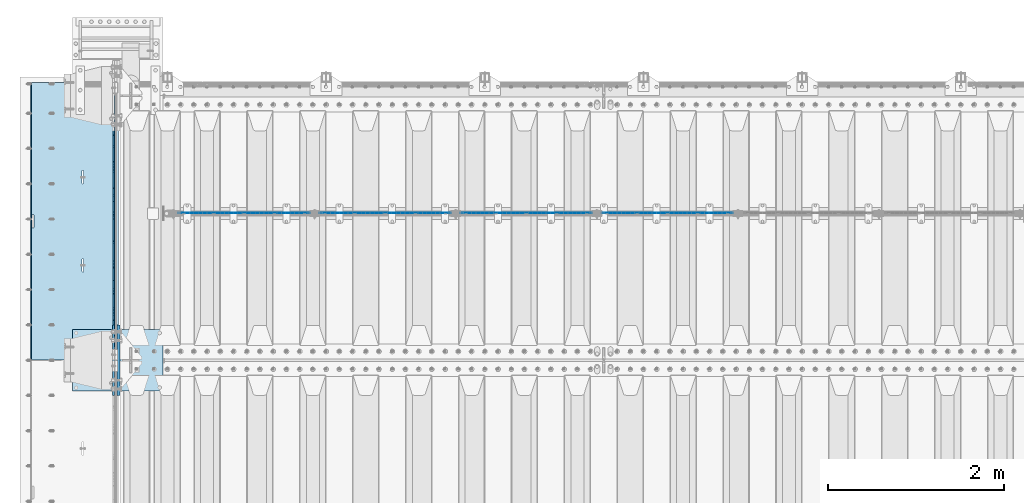
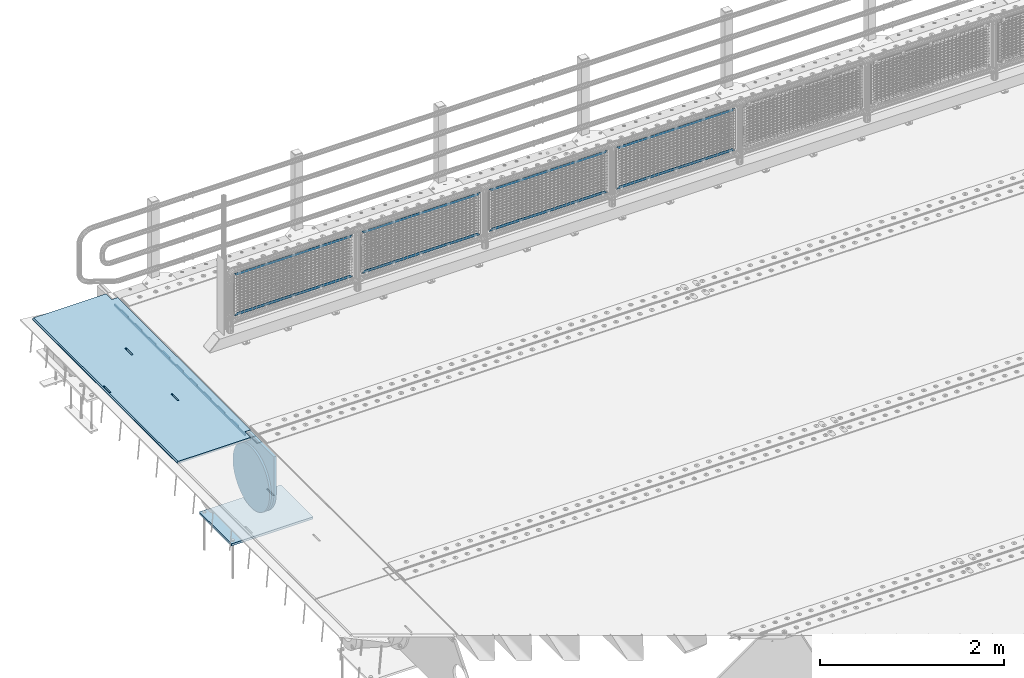
# One storey, part 199 of 257: 13 plates.
"""IFC2X3 building model written with IfcOpenShell, lengths in millimetres."""

from ifc_helpers import new_model, si_unit, frame, origin_with_axes, place, context, subcontext, project, spatial, faceted_brep, material, type_object, element, save


model = new_model("IFC2X3")

# Units and contexts
model_context = context("Model", 3, precision=1e-05, world=origin_with_axes())
body_context = subcontext(model_context, "Body", "Model", "MODEL_VIEW")
ifc_project = project(units=[si_unit("LENGTHUNIT", "METRE", prefix="MILLI"), si_unit("AREAUNIT", "SQUARE_METRE"), si_unit("VOLUMEUNIT", "CUBIC_METRE"), si_unit("MASSUNIT", "GRAM", prefix="KILO"), si_unit("TIMEUNIT", "SECOND"), si_unit("PLANEANGLEUNIT", "RADIAN"), si_unit("SOLIDANGLEUNIT", "STERADIAN"), si_unit("THERMODYNAMICTEMPERATUREUNIT", "DEGREE_CELSIUS"), si_unit("LUMINOUSINTENSITYUNIT", "LUMEN")], contexts=[model_context])

# Site, building, storey
site_placement = place(None, origin_with_axes())
site = spatial("IfcSite", under=ifc_project, at=site_placement, CompositionType="ELEMENT")
building_placement = place(site_placement, origin_with_axes())
building = spatial("IfcBuilding", under=site, at=building_placement, Name="Standard", CompositionType="ELEMENT")
storey_placement = place(building_placement, origin_with_axes())
storey = spatial("IfcBuildingStorey", under=building, at=storey_placement, Name="Undefined", CompositionType="ELEMENT", Elevation=0.0)

# Plates
ifc_material_1 = material(Name="STEEL/S355N")
plate_type_1 = type_object("IfcPlateType", PredefinedType="NOTDEFINED")
plate_1_placement = place(storey_placement, frame((42392.5, 12002.5000993725, -35.9858217417067), z_axis=(0.0, -0.999999999987744, -4.95099999993769e-06), x_axis=(0.0, 4.9510000093107e-06, -0.999999999987744)))
element("IfcPlate", 1, at=plate_1_placement, inside=storey, type_object=plate_type_1, material=ifc_material_1, context=body_context, shape_type="Brep", body=[
    faceted_brep([(7.105427357601e-15, -7.5, 0.0), (5.96145355302724e-12, -7.5, 150.0), (5.96145355302724e-12, 7.5, 150.0), (7.105427357601e-15, 7.5, 0.0), (-15.0000000000013, -7.5, 150.0), (-15.0000000000013, 7.5, 150.0), (-15.0000000000026, -7.5, 300.0), (-15.0000000000026, 7.5, 300.0), (1.00826014204358e-11, -7.5, 300.0), (1.00826014204358e-11, 7.5, 300.0), (1.05870867628255e-11, -7.5, 450.0), (1.05870867628255e-11, 7.5, 450.0), (-15.000000000004, -7.5, 450.0), (-15.000000000004, 7.5, 450.0), (-15.0000000000053, -7.5, 600.0), (-15.0000000000053, 7.5, 600.0), (1.65343294611375e-11, -7.5, 600.0), (1.65343294611375e-11, 7.5, 600.0), (1.88506987797155e-11, -7.5, 750.0), (1.88506987797155e-11, 7.5, 750.0), (-15.0000000000066, -7.5, 750.0), (-15.0000000000066, 7.5, 750.0), (-15.0000000000079, -7.5, 900.0), (-15.0000000000079, 7.5, 900.0), (2.48050469053851e-11, -7.5, 900.0), (2.48050469053851e-11, 7.5, 900.0), (2.7121416223963e-11, -7.5, 1050.0), (2.7121416223963e-11, 7.5, 1050.0), (-15.0000000000093, -7.5, 1050.0), (-15.0000000000093, 7.5, 1050.0), (-15.0000000000106, -7.5, 1200.0), (-15.0000000000106, 7.5, 1200.0), (3.12638803734444e-11, -7.5, 1200.0), (3.12638803734444e-11, 7.5, 1200.0), (3.53921336682106e-11, -7.5, 1350.0), (3.53921336682106e-11, 7.5, 1350.0), (-15.0000000000119, -7.5, 1350.0), (-15.0000000000119, 7.5, 1350.0), (-15.0000000000132, -7.5, 1500.0), (-15.0000000000132, 7.5, 1500.0), (3.77085029867885e-11, -7.5, 1500.0), (3.77085029867885e-11, 7.5, 1500.0), (4.36628511124582e-11, -7.5, 1650.0), (4.36628511124582e-11, 7.5, 1650.0), (-15.0000000000145, -7.5, 1650.0), (-15.0000000000145, 7.5, 1650.0), (-15.0000000000159, -7.5, 1800.0), (-15.0000000000159, 7.5, 1800.0), (4.41531256001326e-11, -7.5, 1800.0), (4.41531256001326e-11, 7.5, 1800.0), (4.82884843222564e-11, -7.5, 1950.0), (4.82884843222564e-11, 7.5, 1950.0), (-15.0000000000172, -7.5, 1950.0), (-15.0000000000172, 7.5, 1950.0), (-15.0000000000185, -7.5, 2100.0), (-15.0000000000185, 7.5, 2100.0), (5.24309484717378e-11, -7.5, 2100.0), (5.24309484717378e-11, 7.5, 2100.0), (5.47402123629581e-11, -7.5, 2250.0), (5.47402123629581e-11, 7.5, 2250.0), (-15.0000000000198, -7.5, 2250.0), (-15.0000000000198, 7.5, 2250.0), (-15.0000000000212, -7.5, 2400.0), (-15.0000000000212, 7.5, 2400.0), (6.06945604886278e-11, -7.5, 2400.0), (6.06945604886278e-11, 7.5, 2400.0), (6.30038243798481e-11, -7.5, 2550.0), (6.30038243798481e-11, 7.5, 2550.0), (-15.0000000000225, -7.5, 2550.0), (-15.0000000000225, 7.5, 2550.0), (-15.0000000000238, -7.5, 2700.0), (-15.0000000000238, 7.5, 2700.0), (6.53272991257836e-11, -7.5, 2700.0), (6.53272991257836e-11, 7.5, 2700.0), (7.12745418240957e-11, -7.5, 2850.0), (7.12745418240957e-11, 7.5, 2850.0), (24.9999999999749, -7.5, 2850.0), (24.9999999999749, 7.5, 2850.0), (25.0, -7.5, 0.0), (25.0, 7.5, 0.0)], [[[0, 1, 2, 3]], [[1, 4, 5, 2]], [[4, 6, 7, 5]], [[6, 8, 9, 7]], [[8, 10, 11, 9]], [[10, 12, 13, 11]], [[12, 14, 15, 13]], [[14, 16, 17, 15]], [[16, 18, 19, 17]], [[18, 20, 21, 19]], [[20, 22, 23, 21]], [[22, 24, 25, 23]], [[24, 26, 27, 25]], [[26, 28, 29, 27]], [[28, 30, 31, 29]], [[30, 32, 33, 31]], [[32, 34, 35, 33]], [[34, 36, 37, 35]], [[36, 38, 39, 37]], [[38, 40, 41, 39]], [[40, 42, 43, 41]], [[42, 44, 45, 43]], [[44, 46, 47, 45]], [[46, 48, 49, 47]], [[48, 50, 51, 49]], [[50, 52, 53, 51]], [[52, 54, 55, 53]], [[54, 56, 57, 55]], [[56, 58, 59, 57]], [[58, 60, 61, 59]], [[60, 62, 63, 61]], [[62, 64, 65, 63]], [[64, 66, 67, 65]], [[66, 68, 69, 67]], [[68, 70, 71, 69]], [[70, 72, 73, 71]], [[72, 74, 75, 73]], [[74, 76, 77, 75]], [[76, 78, 79, 77]], [[78, 0, 3, 79]], [[5, 7, 9, 11, 13, 15, 17, 19, 21, 23, 25, 27, 29, 31, 33, 35, 37, 39, 41, 43, 45, 47, 49, 51, 53, 55, 57, 59, 61, 63, 65, 67, 69, 71, 73, 75, 77, 79, 3, 2]], [[78, 76, 74, 72, 70, 68, 66, 64, 62, 60, 58, 56, 54, 52, 50, 48, 46, 44, 42, 40, 38, 36, 34, 32, 30, 28, 26, 24, 22, 20, 18, 16, 14, 12, 10, 8, 6, 4, 1, 0]]]),
])
plate_type_2 = type_object("IfcPlateType", PredefinedType="NOTDEFINED")
plate_2_placement = place(storey_placement, frame((42444.9962454292, 12149.9999261293, -0.984391683157732), z_axis=(0.0, -0.999999999987744, -4.95099999993769e-06), x_axis=(-0.999999999879068, -1.00000022173607e-09, -1.55519999981193e-05)))
element("IfcPlate", 2, at=plate_2_placement, inside=storey, type_object=plate_type_2, material=ifc_material_1, context=body_context, shape_type="Brep", body=[
    faceted_brep([(14.9998601691696, 15.0, 125.00002482085), (-0.000294611330900807, -0.000806902962787737, 124.999936248651), (-0.00191941577213584, 0.000806844426837205, 3020.00000492305), (14.9966216875109, 15.0, 3020.00007976653), (999.996459960938, 5.0, 1.81898940354586e-12), (984.996459960938, 15.0, 1.81898940354586e-12), (984.996459718779, 15.0, 3145.0), (999.996459718779, 5.0, 3145.0), (984.996459961367, -15.0, 1.81898940354586e-12), (999.996459960938, -4.99999999999848, 1.81898940354586e-12), (999.996459718779, -4.99999999999848, 3145.0), (984.996459719208, -15.0, 3145.0), (74.9997820615899, -15.0, 4.54747350886464e-13), (74.9996421866963, -15.0000000127077, 124.99993008412), (75.0001087166893, 15.0, 125.00007975412), (75.0002485915829, 15.0, 0.0), (-0.000449375191237777, -14.9999999951864, 124.999861417765), (395.48605660427, -15.0000000067239, 2004.40983005397), (395.48605660427, 15.0, 2004.40983005397), (394.996621766979, 15.0, 2007.49999999772), (394.996621766986, -15.0000000067363, 2007.49999999772), (396.906451823685, -15.0000000066914, 2001.6221474748), (396.906451823692, 15.0, 2001.6221474748), (399.118769244691, -15.0000000066418, 1999.40983005397), (399.118769244691, 15.0, 1999.40983005397), (401.906451823968, -15.0000000065801, 1997.98943483477), (401.906451823968, 15.0, 1997.98943483477), (404.996621767765, -15.0000000065123, 1997.49999999772), (404.996621767757, 15.0, 1997.49999999772), (408.086791711357, -15.0000000064451, 1997.98943483477), (408.086791711357, 15.0, 1997.98943483477), (410.874474290416, -15.0000000063849, 1999.40983005397), (410.874474290409, 15.0, 1999.40983005397), (413.086791711066, -15.0000000063378, 2001.62214747479), (413.086791711066, 15.0, 2001.62214747479), (414.507186930059, -15.0000000063082, 2004.40983005396), (414.507186930059, 15.0, 2004.40983005396), (414.99662176687, -15.0000000062992, 2007.49999999771), (414.99662176687, 15.0, 2007.49999999771), (414.996621756974, -15.0000000063698, 2137.49999999771), (414.996621756974, 15.0, 2137.49999999771), (414.507186919691, -15.0000000063821, 2140.59016994146), (414.507186919684, 15.0, 2140.59016994146), (413.086791700262, -15.0000000064147, 2143.37785252064), (413.086791700269, 15.0, 2143.37785252064), (410.87447427927, -15.0000000064642, 2145.59016994147), (410.87447427927, 15.0, 2145.59016994147), (408.086791699992, -15.0000000065259, 2147.01056516067), (408.086791699992, 15.0, 2147.01056516067), (404.996621756196, -15.0000000065937, 2147.49999999772), (404.996621756196, 15.0, 2147.49999999772), (401.906451812494, -15.000000006661, 2147.01056516067), (401.906451812487, 15.0, 2147.01056516067), (399.118769233435, -15.0000000067211, 2145.59016994147), (399.118769233435, 15.0, 2145.59016994147), (396.906451812771, -15.0000000067683, 2143.37785252064), (396.906451812771, 15.0, 2143.37785252064), (395.486056593792, -15.0000000067978, 2140.59016994147), (395.486056593792, 15.0, 2140.59016994147), (394.996621756982, -15.0000000068068, 2137.49999999772), (394.996621756982, 15.0, 2137.49999999772), (960.486056642767, -14.9999999941054, 1504.4098300542), (960.486056642767, 15.0, 1504.4098300542), (959.996621805483, 15.0, 1507.49999999795), (959.996621805483, -14.9999999941178, 1507.49999999795), (961.906451862189, -14.9999999940728, 1501.62214747503), (961.906451862189, 15.0, 1501.62214747503), (964.118769283188, -14.9999999940233, 1499.4098300542), (964.118769283188, 15.0, 1499.4098300542), (966.906451862465, -14.9999999939616, 1497.989434835), (966.906451862473, 15.0, 1497.989434835), (969.996621806255, -14.9999999938938, 1497.49999999795), (969.996621806247, 15.0, 1497.49999999795), (973.086791749854, -14.9999999938266, 1497.989434835), (973.086791749854, 15.0, 1497.989434835), (975.874474328921, -14.9999999937664, 1499.4098300542), (975.874474328913, 15.0, 1499.4098300542), (978.086791749571, -14.9999999937193, 1501.62214747502), (978.086791749571, 15.0, 1501.62214747502), (979.507186968556, -14.9999999936897, 1504.4098300542), (979.507186968556, 15.0, 1504.4098300542), (979.996621805367, -14.9999999936807, 1507.49999999794), (979.996621805367, 15.0, 1507.49999999794), (979.996621795464, -14.9999999937513, 1637.49999999794), (979.996621795464, 15.0, 1637.49999999794), (979.507186958173, -14.9999999937636, 1640.59016994169), (979.507186958181, 15.0, 1640.59016994169), (978.086791738773, -14.9999999937962, 1643.37785252087), (978.086791738773, 15.0, 1643.37785252087), (975.874474317774, -14.9999999938457, 1645.5901699417), (975.874474317774, 15.0, 1645.5901699417), (973.086791738489, -14.9999999939074, 1647.0105651609), (973.086791738489, 15.0, 1647.0105651609), (969.996621794693, -14.9999999939752, 1647.49999999795), (969.9966217947, 15.0, 1647.49999999795), (966.906451850991, -14.9999999940425, 1647.0105651609), (966.906451850991, 15.0, 1647.0105651609), (964.118769271932, -14.9999999941026, 1645.5901699417), (964.118769271932, 15.0, 1645.5901699417), (961.906451851275, -14.9999999941498, 1643.37785252088), (961.906451851275, 15.0, 1643.37785252088), (960.486056632282, -14.9999999941793, 1640.5901699417), (960.486056632282, 15.0, 1640.5901699417), (959.996621795472, -14.9999999941883, 1637.49999999795), (959.996621795472, 15.0, 1637.49999999795), (74.9967306509934, 15.0, 3145.0), (74.9962640909871, -15.0, 3145.0), (74.9968705258798, 15.0, 3020.00007982413), (74.9964039658807, -15.0, 3019.99993015413), (-0.00046036208368605, -15.00000004538, 3019.99993008592), (395.486056670779, -15.0000000062551, 1140.59016994195), (396.906451889765, -15.0000000062256, 1143.37785252113), (399.118769310422, -15.0000000061784, 1145.59016994195), (401.906451889496, -15.0000000061183, 1147.01056516115), (404.996621833197, -15.000000006051, 1147.4999999982), (408.086791776987, -15.0000000059832, 1147.01056516115), (410.874474356264, -15.0000000059215, 1145.59016994195), (413.086791777263, -15.000000005872, 1143.37785252112), (414.507186996678, -15.0000000058394, 1140.59016994194), (414.996621833961, -15.0000000058271, 1137.49999999819), (414.996621843864, -15.0000000057565, 1007.49999999819), (414.507187007053, -15.0000000057655, 1004.40983005444), (413.086791788061, -15.0000000057951, 1001.62214747527), (410.874474367411, -15.0000000058422, 999.409830054449), (408.086791788344, -15.0000000059024, 997.989434835249), (404.996621844752, -15.0000000059696, 997.499999998201), (401.906451900963, -15.0000000060374, 997.989434835249), (399.118769321678, -15.0000000060991, 999.409830054451), (396.906451900679, -15.0000000061487, 1001.62214747528), (395.486056681264, -15.0000000061812, 1004.40983005445), (394.996621843988, -15.0000000061936, 1007.4999999982), (394.996621833969, -15.0000000062641, 1137.4999999982), (396.906451900679, 15.0, 1001.62214747528), (395.486056681264, 15.0, 1004.40983005445), (399.118769321678, 15.0, 999.409830054451), (401.906451900963, 15.0, 997.989434835249), (404.996621844744, 15.0, 997.499999998201), (408.086791788344, 15.0, 997.989434835249), (410.874474367403, 15.0, 999.409830054449), (413.086791788061, 15.0, 1001.62214747527), (414.507187007061, 15.0, 1004.40983005444), (414.996621843871, 15.0, 1007.49999999819), (414.996621833961, 15.0, 1137.49999999819), (414.507186996678, 15.0, 1140.59016994194), (413.086791777263, 15.0, 1143.37785252112), (410.874474356264, 15.0, 1145.59016994195), (408.086791776987, 15.0, 1147.01056516115), (404.996621833197, 15.0, 1147.4999999982), (401.906451889488, 15.0, 1147.01056516115), (399.118769310422, 15.0, 1145.59016994195), (396.906451889765, 15.0, 1143.37785252113), (395.486056670779, 15.0, 1140.59016994195), (394.996621833969, 15.0, 1137.4999999982), (394.99662184398, 15.0, 1007.4999999982)], [[[0, 1, 2, 3]], [[4, 5, 6, 7]], [[8, 9, 10, 11]], [[12, 13, 14, 15]], [[14, 13, 16, 1, 0]], [[17, 18, 19, 20]], [[21, 22, 18, 17]], [[23, 24, 22, 21]], [[25, 26, 24, 23]], [[27, 28, 26, 25]], [[29, 30, 28, 27]], [[31, 32, 30, 29]], [[33, 34, 32, 31]], [[35, 36, 34, 33]], [[37, 38, 36, 35]], [[39, 40, 38, 37]], [[41, 42, 40, 39]], [[43, 44, 42, 41]], [[45, 46, 44, 43]], [[47, 48, 46, 45]], [[49, 50, 48, 47]], [[51, 52, 50, 49]], [[53, 54, 52, 51]], [[55, 56, 54, 53]], [[57, 58, 56, 55]], [[59, 60, 58, 57]], [[20, 19, 60, 59]], [[61, 62, 63, 64]], [[65, 66, 62, 61]], [[67, 68, 66, 65]], [[69, 70, 68, 67]], [[71, 72, 70, 69]], [[73, 74, 72, 71]], [[75, 76, 74, 73]], [[77, 78, 76, 75]], [[79, 80, 78, 77]], [[81, 82, 80, 79]], [[83, 84, 82, 81]], [[85, 86, 84, 83]], [[87, 88, 86, 85]], [[89, 90, 88, 87]], [[91, 92, 90, 89]], [[93, 94, 92, 91]], [[95, 96, 94, 93]], [[97, 98, 96, 95]], [[99, 100, 98, 97]], [[101, 102, 100, 99]], [[103, 104, 102, 101]], [[64, 63, 104, 103]], [[9, 8, 12, 15, 5, 4]], [[10, 9, 4, 7]], [[105, 106, 11, 10, 7, 6]], [[106, 105, 107, 108]], [[109, 108, 107, 3, 2]], [[106, 108, 109, 16, 13, 12, 8, 11], [101, 99, 97, 95, 93, 91, 89, 87, 85, 83, 81, 79, 77, 75, 73, 71, 69, 67, 65, 61, 64, 103], [57, 55, 53, 51, 49, 47, 45, 43, 41, 39, 37, 35, 33, 31, 29, 27, 25, 23, 21, 17, 20, 59], [110, 111, 112, 113, 114, 115, 116, 117, 118, 119, 120, 121, 122, 123, 124, 125, 126, 127, 128, 129, 130, 131]], [[128, 132, 133, 129]], [[127, 134, 132, 128]], [[126, 135, 134, 127]], [[125, 136, 135, 126]], [[124, 137, 136, 125]], [[123, 138, 137, 124]], [[122, 139, 138, 123]], [[121, 140, 139, 122]], [[120, 141, 140, 121]], [[119, 142, 141, 120]], [[118, 143, 142, 119]], [[117, 144, 143, 118]], [[116, 145, 144, 117]], [[115, 146, 145, 116]], [[114, 147, 146, 115]], [[113, 148, 147, 114]], [[112, 149, 148, 113]], [[111, 150, 149, 112]], [[110, 151, 150, 111]], [[131, 152, 151, 110]], [[130, 153, 152, 131]], [[129, 133, 153, 130]], [[107, 105, 6, 5, 15, 14, 0, 3], [132, 134, 135, 136, 137, 138, 139, 140, 141, 142, 143, 144, 145, 146, 147, 148, 149, 150, 151, 152, 153, 133], [22, 24, 26, 28, 30, 32, 34, 36, 38, 40, 42, 44, 46, 48, 50, 52, 54, 56, 58, 60, 19, 18], [66, 68, 70, 72, 74, 76, 78, 80, 82, 84, 86, 88, 90, 92, 94, 96, 98, 100, 102, 104, 63, 62]], [[16, 109, 2, 1]]]),
])
ifc_material_2 = material(Name="Misc_Undefined")
plate_type_3 = type_object("IfcPlateType", PredefinedType="NOTDEFINED")
plate_3_placement = place(storey_placement, frame((47924.5050117304, 10670.5, 351.520303374641), z_axis=(0.0, 0.0, 1.0), x_axis=(1.0, 0.0, 0.0)))
element("IfcPlate", 3, at=plate_3_placement, inside=storey, type_object=plate_type_3, material=ifc_material_2, context=body_context, shape_type="Brep", body=[
    faceted_brep([(0.0, -1.5, -5.6843418860808e-14), (35.0002975463867, -1.5, 34.9996948242187), (35.0002975463867, 1.5, 34.9996948242187), (0.0, 1.5, -5.6843418860808e-14), (1457.99035644531, -1.5, 34.9999923706054), (1457.99035644531, 1.5, 34.9999923706054), (1492.98999023438, -1.5, -2.87985812974512e-09), (1492.98999023438, 1.5, -2.87985812974512e-09)], [[[0, 1, 2, 3]], [[1, 4, 5, 2]], [[4, 6, 7, 5]], [[6, 0, 3, 7]], [[5, 7, 3, 2]], [[6, 4, 1, 0]]]),
])
plate_4_placement = place(storey_placement, frame((49417.5000001876, 10670.5, 914.520000175701), z_axis=(-0.707103624179501, 0.0, 0.707109938179499), x_axis=(-0.707109938179488, 0.0, -0.707103624179512)))
element("IfcPlate", 4, at=plate_4_placement, inside=storey, type_object=plate_type_3, material=ifc_material_2, context=body_context, shape_type="Brep", body=[
    faceted_brep([(0.0, -1.5, -5.6843418860808e-14), (1055.71520996094, -1.5, 1055.70581054687), (1055.71520996094, 1.5, 1055.70581054687), (0.0, 1.5, -5.6843418860808e-14), (1055.70812988282, -1.5, 1006.20135498046), (1055.70812988282, 1.5, 1006.20135498046), (49.4976959228443, -1.5, 6.54836185276508e-11), (49.4976959228443, 1.5, 6.54836185276508e-11)], [[[0, 1, 2, 3]], [[1, 4, 5, 2]], [[4, 6, 7, 5]], [[6, 0, 3, 7]], [[5, 7, 3, 2]], [[6, 4, 1, 0]]]),
])
plate_5_placement = place(storey_placement, frame((46324.5050117304, 10670.5, 351.520303374641), z_axis=(0.0, 0.0, 1.0), x_axis=(1.0, 0.0, 0.0)))
element("IfcPlate", 5, at=plate_5_placement, inside=storey, type_object=plate_type_3, material=ifc_material_2, context=body_context, shape_type="Brep", body=[
    faceted_brep([(0.0, -1.5, -5.6843418860808e-14), (35.0002975463867, -1.5, 34.9996948242187), (35.0002975463867, 1.5, 34.9996948242187), (0.0, 1.5, -5.6843418860808e-14), (1457.99035644531, -1.5, 34.9999923706054), (1457.99035644531, 1.5, 34.9999923706054), (1492.98999023438, -1.5, -2.87985812974512e-09), (1492.98999023438, 1.5, -2.87985812974512e-09)], [[[0, 1, 2, 3]], [[1, 4, 5, 2]], [[4, 6, 7, 5]], [[6, 0, 3, 7]], [[5, 7, 3, 2]], [[6, 4, 1, 0]]]),
])
plate_6_placement = place(storey_placement, frame((47817.5000001876, 10670.5, 914.520000175701), z_axis=(-0.707103624179501, 0.0, 0.707109938179499), x_axis=(-0.707109938179488, 0.0, -0.707103624179512)))
element("IfcPlate", 6, at=plate_6_placement, inside=storey, type_object=plate_type_3, material=ifc_material_2, context=body_context, shape_type="Brep", body=[
    faceted_brep([(0.0, -1.5, -5.6843418860808e-14), (1055.71520996094, -1.5, 1055.70581054687), (1055.71520996094, 1.5, 1055.70581054687), (0.0, 1.5, -5.6843418860808e-14), (1055.70812988282, -1.5, 1006.20135498046), (1055.70812988282, 1.5, 1006.20135498046), (49.4976959228443, -1.5, 6.54836185276508e-11), (49.4976959228443, 1.5, 6.54836185276508e-11)], [[[0, 1, 2, 3]], [[1, 4, 5, 2]], [[4, 6, 7, 5]], [[6, 0, 3, 7]], [[5, 7, 3, 2]], [[6, 4, 1, 0]]]),
])
plate_7_placement = place(storey_placement, frame((44724.5050117304, 10670.5, 351.520303374641), z_axis=(0.0, 0.0, 1.0), x_axis=(1.0, 0.0, 0.0)))
element("IfcPlate", 7, at=plate_7_placement, inside=storey, type_object=plate_type_3, material=ifc_material_2, context=body_context, shape_type="Brep", body=[
    faceted_brep([(0.0, -1.5, -5.6843418860808e-14), (35.0002975463867, -1.5, 34.9996948242187), (35.0002975463867, 1.5, 34.9996948242187), (0.0, 1.5, -5.6843418860808e-14), (1457.99035644531, -1.5, 34.9999923706054), (1457.99035644531, 1.5, 34.9999923706054), (1492.98999023438, -1.5, -2.87985812974512e-09), (1492.98999023438, 1.5, -2.87985812974512e-09)], [[[0, 1, 2, 3]], [[1, 4, 5, 2]], [[4, 6, 7, 5]], [[6, 0, 3, 7]], [[5, 7, 3, 2]], [[6, 4, 1, 0]]]),
])
plate_8_placement = place(storey_placement, frame((46217.5000001876, 10670.5, 914.520000175701), z_axis=(-0.707103624179501, 0.0, 0.707109938179499), x_axis=(-0.707109938179488, 0.0, -0.707103624179512)))
element("IfcPlate", 8, at=plate_8_placement, inside=storey, type_object=plate_type_3, material=ifc_material_2, context=body_context, shape_type="Brep", body=[
    faceted_brep([(0.0, -1.5, -5.6843418860808e-14), (1055.71520996094, -1.5, 1055.70581054687), (1055.71520996094, 1.5, 1055.70581054687), (0.0, 1.5, -5.6843418860808e-14), (1055.70812988282, -1.5, 1006.20135498046), (1055.70812988282, 1.5, 1006.20135498046), (49.4976959228443, -1.5, 6.54836185276508e-11), (49.4976959228443, 1.5, 6.54836185276508e-11)], [[[0, 1, 2, 3]], [[1, 4, 5, 2]], [[4, 6, 7, 5]], [[6, 0, 3, 7]], [[5, 7, 3, 2]], [[6, 4, 1, 0]]]),
])
plate_9_placement = place(storey_placement, frame((43124.5050117304, 10670.5, 351.520303374641), z_axis=(0.0, 0.0, 1.0), x_axis=(1.0, 0.0, 0.0)))
element("IfcPlate", 9, at=plate_9_placement, inside=storey, type_object=plate_type_3, material=ifc_material_2, context=body_context, shape_type="Brep", body=[
    faceted_brep([(0.0, -1.5, -5.6843418860808e-14), (35.0002975463867, -1.5, 34.9996948242187), (35.0002975463867, 1.5, 34.9996948242187), (0.0, 1.5, -5.6843418860808e-14), (1457.99035644531, -1.5, 34.9999923706054), (1457.99035644531, 1.5, 34.9999923706054), (1492.98999023438, -1.5, -2.87985812974512e-09), (1492.98999023438, 1.5, -2.87985812974512e-09)], [[[0, 1, 2, 3]], [[1, 4, 5, 2]], [[4, 6, 7, 5]], [[6, 0, 3, 7]], [[5, 7, 3, 2]], [[6, 4, 1, 0]]]),
])
plate_10_placement = place(storey_placement, frame((44617.5000001876, 10670.5, 914.520000175701), z_axis=(-0.707103624179501, 0.0, 0.707109938179499), x_axis=(-0.707109938179488, 0.0, -0.707103624179512)))
element("IfcPlate", 10, at=plate_10_placement, inside=storey, type_object=plate_type_3, material=ifc_material_2, context=body_context, shape_type="Brep", body=[
    faceted_brep([(0.0, -1.5, -5.6843418860808e-14), (1055.71520996094, -1.5, 1055.70581054687), (1055.71520996094, 1.5, 1055.70581054687), (0.0, 1.5, -5.6843418860808e-14), (1055.70812988282, -1.5, 1006.20135498046), (1055.70812988282, 1.5, 1006.20135498046), (49.4976959228443, -1.5, 6.54836185276508e-11), (49.4976959228443, 1.5, 6.54836185276508e-11)], [[[0, 1, 2, 3]], [[1, 4, 5, 2]], [[4, 6, 7, 5]], [[6, 0, 3, 7]], [[5, 7, 3, 2]], [[6, 4, 1, 0]]]),
])
plate_type_4 = type_object("IfcPlateType", PredefinedType="NOTDEFINED")
plate_11_placement = place(storey_placement, frame((42445.0, 8600.0, -20.0), z_axis=(0.0, 1.0, 0.0), x_axis=(0.0, 0.0, -1.0)))
element("IfcPlate", 11, at=plate_11_placement, inside=storey, type_object=plate_type_4, material=ifc_material_1, context=body_context, shape_type="Brep", body=[
    faceted_brep([(855.0, -15.0, 572.96311467154), (855.0, 15.0, 572.96311467154), (849.182410261294, 15.0, 585.889268817531), (849.182410261294, -15.0, 585.889268817531), (824.193546357474, 15.0, 627.225898692485), (824.193546357474, -15.0, 627.225898692485), (794.404299268454, 15.0, 665.249063296341), (794.404299268454, -15.0, 665.249063296341), (760.249063296334, 15.0, 699.404299268464), (760.249063296334, -15.0, 699.404299268464), (722.22589869248, 15.0, 729.193546357486), (722.22589869248, -15.0, 729.193546357486), (680.889268817528, 15.0, 754.182410261309), (680.889268817528, -15.0, 754.182410261309), (636.841954817037, 15.0, 774.006497074193), (636.841954817037, -15.0, 774.006497074193), (590.726265715048, 15.0, 788.37672697045), (590.726265715048, -15.0, 788.37672697045), (543.214672102156, 15.0, 797.083549639254), (543.214672102156, -15.0, 797.083549639254), (495.0, -15.0, 800.000000000029), (495.0, 15.0, 800.0), (494.999999999412, -15.0, 0.0), (494.999999999412, 15.0, 0.0), (543.214672102129, 15.0, 2.91645036080718), (543.214672102129, -15.0, 2.91645036080718), (590.726265715023, 15.0, 11.6232730296088), (590.726265715023, -15.0, 11.6232730296088), (636.841954817014, 15.0, 25.9935029258631), (636.841954817014, -15.0, 25.9935029258631), (680.889268817507, 15.0, 45.8175897387455), (680.889268817507, -15.0, 45.8175897387455), (722.225898692462, 15.0, 70.8064536425663), (722.225898692462, -15.0, 70.8064536425663), (760.249063296318, 15.0, 100.595700731588), (760.249063296318, -15.0, 100.595700731588), (794.404299268441, 15.0, 134.750936703711), (794.404299268441, -15.0, 134.750936703711), (824.193546357463, 15.0, 172.774101307567), (824.193546357463, -15.0, 172.774101307567), (849.182410261284, 15.0, 214.110731182522), (849.182410261284, -15.0, 214.110731182522), (855.0, -15.0, 227.036885328535), (855.0, 15.0, 227.036885328535), (0.0, -15.0, 0.0), (0.0, 15.0, 0.0), (0.0, 15.0, 800.0), (0.0, -15.0, 800.0)], [[[0, 1, 2, 3]], [[3, 2, 4, 5]], [[5, 4, 6, 7]], [[7, 6, 8, 9]], [[9, 8, 10, 11]], [[11, 10, 12, 13]], [[13, 12, 14, 15]], [[15, 14, 16, 17]], [[17, 16, 18, 19]], [[20, 19, 18, 21]], [[22, 23, 24, 25]], [[25, 24, 26, 27]], [[27, 26, 28, 29]], [[29, 28, 30, 31]], [[31, 30, 32, 33]], [[33, 32, 34, 35]], [[35, 34, 36, 37]], [[37, 36, 38, 39]], [[39, 38, 40, 41]], [[42, 41, 40, 43]], [[42, 43, 1, 0]], [[44, 45, 23, 22]], [[16, 14, 12, 10, 8, 6, 4, 2, 1, 43, 40, 38, 36, 34, 32, 30, 28, 26, 24, 23, 45, 46, 21, 18]], [[44, 47, 46, 45]], [[46, 47, 20, 21]], [[47, 44, 22, 25, 27, 29, 31, 33, 35, 37, 39, 41, 42, 0, 3, 5, 7, 9, 11, 13, 15, 17, 19, 20]]]),
])
plate_type_5 = type_object("IfcPlateType", PredefinedType="NOTDEFINED")
plate_12_placement = place(storey_placement, frame((41926.0, 9350.0, -1043.0), z_axis=(1.0, 0.0, 0.0), x_axis=(0.0, -1.0, 0.0)))
element("IfcPlate", 12, at=plate_12_placement, inside=storey, type_object=plate_type_5, material=ifc_material_1, context=body_context, shape_type="Brep", body=[
    faceted_brep([(0.0, -15.0, 0.0), (3.03448287013453e-05, -15.0, 1025.0), (3.03448287013453e-05, 15.0, 1025.0), (0.0, 15.0, 0.0), (700.0, -15.0, 1025.0), (700.0, 15.0, 1025.0), (700.0, -15.0, -7.27595761418343e-12), (700.0, 15.0, -7.27595761418343e-12)], [[[0, 1, 2, 3]], [[1, 4, 5, 2]], [[4, 6, 7, 5]], [[6, 0, 3, 7]], [[5, 7, 3, 2]], [[6, 4, 1, 0]]]),
])
plate_type_6 = type_object("IfcPlateType", PredefinedType="NOTDEFINED")
plate_13_placement = place(storey_placement, frame((42387.5, 9400.0, -114.999999999998), z_axis=(0.0, 0.0, -1.0), x_axis=(0.0, -1.0, 0.0)))
element("IfcPlate", 13, at=plate_13_placement, inside=storey, type_object=plate_type_6, material=ifc_material_1, context=body_context, shape_type="Brep", body=[
    faceted_brep([(-1.13686837721616e-13, -12.5, 400.0), (2.91645036077841, -12.5, 448.214672102129), (2.91645036077841, 12.5, 448.214672102129), (-1.13686837721616e-13, 12.5, 400.0), (11.6232730295792, -12.5, 495.726265715023), (11.6232730295792, 12.5, 495.726265715023), (25.993502925834, -12.5, 541.841954817014), (25.993502925834, 12.5, 541.841954817014), (45.817589738716, -12.5, 585.889268817507), (45.817589738716, 12.5, 585.889268817507), (70.8064536425373, -12.5, 627.225898692462), (70.8064536425373, 12.5, 627.225898692462), (100.595700731559, -12.5, 665.249063296318), (100.595700731559, 12.5, 665.249063296318), (134.750936703682, -12.5, 699.40429926844), (134.750936703682, 12.5, 699.40429926844), (172.774101307538, -12.5, 729.193546357462), (172.774101307538, 12.5, 729.193546357462), (214.110731182492, -12.5, 754.182410261284), (214.110731182492, 12.5, 754.182410261284), (258.158045182986, -12.5, 774.006497074166), (258.158045182986, 12.5, 774.006497074166), (304.273734284977, -12.5, 788.376726970421), (304.273734284977, 12.5, 788.376726970421), (351.78532789787, -12.5, 797.083549639221), (351.78532789787, 12.5, 797.083549639221), (400.0, -12.5, 800.0), (400.0, 12.5, 800.0), (448.214672102129, -12.5, 797.083549639222), (448.214672102129, 12.5, 797.083549639222), (495.726265715023, -12.5, 788.376726970421), (495.726265715023, 12.5, 788.376726970421), (541.841954817014, -12.5, 774.006497074166), (541.841954817014, 12.5, 774.006497074166), (585.889268817507, -12.5, 754.182410261284), (585.889268817507, 12.5, 754.182410261284), (627.225898692462, -12.5, 729.193546357463), (627.225898692462, 12.5, 729.193546357463), (665.249063296318, -12.5, 699.404299268441), (665.249063296318, 12.5, 699.404299268441), (699.40429926844, -12.5, 665.249063296318), (699.40429926844, 12.5, 665.249063296318), (729.193546357463, -12.5, 627.225898692462), (729.193546357463, 12.5, 627.225898692462), (754.182410261284, -12.5, 585.889268817507), (754.182410261284, 12.5, 585.889268817507), (774.006497074166, -12.5, 541.841954817014), (774.006497074166, 12.5, 541.841954817014), (788.376726970421, -12.5, 495.726265715023), (788.376726970421, 12.5, 495.726265715023), (797.083549639222, -12.5, 448.214672102129), (797.083549639222, 12.5, 448.214672102129), (800.0, -12.5, 400.0), (800.0, 12.5, 400.0), (797.083549639222, -12.5, 351.785327897871), (797.083549639222, 12.5, 351.785327897871), (788.376726970421, -12.5, 304.273734284977), (788.376726970421, 12.5, 304.273734284977), (774.006497074166, -12.5, 258.158045182986), (774.006497074166, 12.5, 258.158045182986), (754.182410261284, -12.5, 214.110731182493), (754.182410261284, 12.5, 214.110731182493), (729.193546357463, -12.5, 172.774101307538), (729.193546357463, 12.5, 172.774101307538), (699.40429926844, -12.5, 134.750936703682), (699.40429926844, 12.5, 134.750936703682), (665.249063296318, -12.5, 100.59570073156), (665.249063296318, 12.5, 100.59570073156), (627.225898692462, -12.5, 70.8064536425375), (627.225898692462, 12.5, 70.8064536425375), (585.889268817507, -12.5, 45.817589738716), (585.889268817507, 12.5, 45.817589738716), (541.841954817014, -12.5, 25.9935029258342), (541.841954817014, 12.5, 25.9935029258342), (495.726265715023, -12.5, 11.6232730295793), (495.726265715023, 12.5, 11.6232730295793), (448.214672102129, -12.5, 2.91645036077847), (448.214672102129, 12.5, 2.91645036077847), (400.0, -12.5, -5.6843418860808e-14), (400.0, 12.5, -5.6843418860808e-14), (351.785327897871, -12.5, 2.91645036077836), (351.785327897871, 12.5, 2.91645036077836), (304.273734284977, -12.5, 11.6232730295792), (304.273734284977, 12.5, 11.6232730295792), (258.158045182986, -12.5, 25.993502925834), (258.158045182986, 12.5, 25.993502925834), (214.110731182492, -12.5, 45.817589738716), (214.110731182492, 12.5, 45.817589738716), (172.774101307538, -12.5, 70.8064536425374), (172.774101307538, 12.5, 70.8064536425374), (134.750936703682, -12.5, 100.595700731559), (134.750936703682, 12.5, 100.595700731559), (100.59570073156, -12.5, 134.750936703682), (100.59570073156, 12.5, 134.750936703682), (70.8064536425373, -12.5, 172.774101307538), (70.8064536425373, 12.5, 172.774101307538), (45.817589738716, -12.5, 214.110731182492), (45.817589738716, 12.5, 214.110731182492), (25.993502925834, -12.5, 258.158045182986), (25.993502925834, 12.5, 258.158045182986), (11.6232730295791, -12.5, 304.273734284977), (11.6232730295791, 12.5, 304.273734284977), (2.91645036077836, -12.5, 351.785327897871), (2.91645036077836, 12.5, 351.785327897871)], [[[0, 1, 2, 3]], [[1, 4, 5, 2]], [[4, 6, 7, 5]], [[6, 8, 9, 7]], [[8, 10, 11, 9]], [[10, 12, 13, 11]], [[12, 14, 15, 13]], [[14, 16, 17, 15]], [[16, 18, 19, 17]], [[18, 20, 21, 19]], [[20, 22, 23, 21]], [[22, 24, 25, 23]], [[24, 26, 27, 25]], [[26, 28, 29, 27]], [[28, 30, 31, 29]], [[30, 32, 33, 31]], [[32, 34, 35, 33]], [[34, 36, 37, 35]], [[36, 38, 39, 37]], [[38, 40, 41, 39]], [[40, 42, 43, 41]], [[42, 44, 45, 43]], [[44, 46, 47, 45]], [[46, 48, 49, 47]], [[48, 50, 51, 49]], [[50, 52, 53, 51]], [[52, 54, 55, 53]], [[54, 56, 57, 55]], [[56, 58, 59, 57]], [[58, 60, 61, 59]], [[60, 62, 63, 61]], [[62, 64, 65, 63]], [[64, 66, 67, 65]], [[66, 68, 69, 67]], [[68, 70, 71, 69]], [[70, 72, 73, 71]], [[72, 74, 75, 73]], [[74, 76, 77, 75]], [[76, 78, 79, 77]], [[78, 80, 81, 79]], [[80, 82, 83, 81]], [[82, 84, 85, 83]], [[84, 86, 87, 85]], [[86, 88, 89, 87]], [[88, 90, 91, 89]], [[90, 92, 93, 91]], [[92, 94, 95, 93]], [[94, 96, 97, 95]], [[96, 98, 99, 97]], [[98, 100, 101, 99]], [[100, 102, 103, 101]], [[102, 0, 3, 103]], [[5, 7, 9, 11, 13, 15, 17, 19, 21, 23, 25, 27, 29, 31, 33, 35, 37, 39, 41, 43, 45, 47, 49, 51, 53, 55, 57, 59, 61, 63, 65, 67, 69, 71, 73, 75, 77, 79, 81, 83, 85, 87, 89, 91, 93, 95, 97, 99, 101, 103, 3, 2]], [[102, 100, 98, 96, 94, 92, 90, 88, 86, 84, 82, 80, 78, 76, 74, 72, 70, 68, 66, 64, 62, 60, 58, 56, 54, 52, 50, 48, 46, 44, 42, 40, 38, 36, 34, 32, 30, 28, 26, 24, 22, 20, 18, 16, 14, 12, 10, 8, 6, 4, 1, 0]]]),
])

save(model, "model.ifc")
